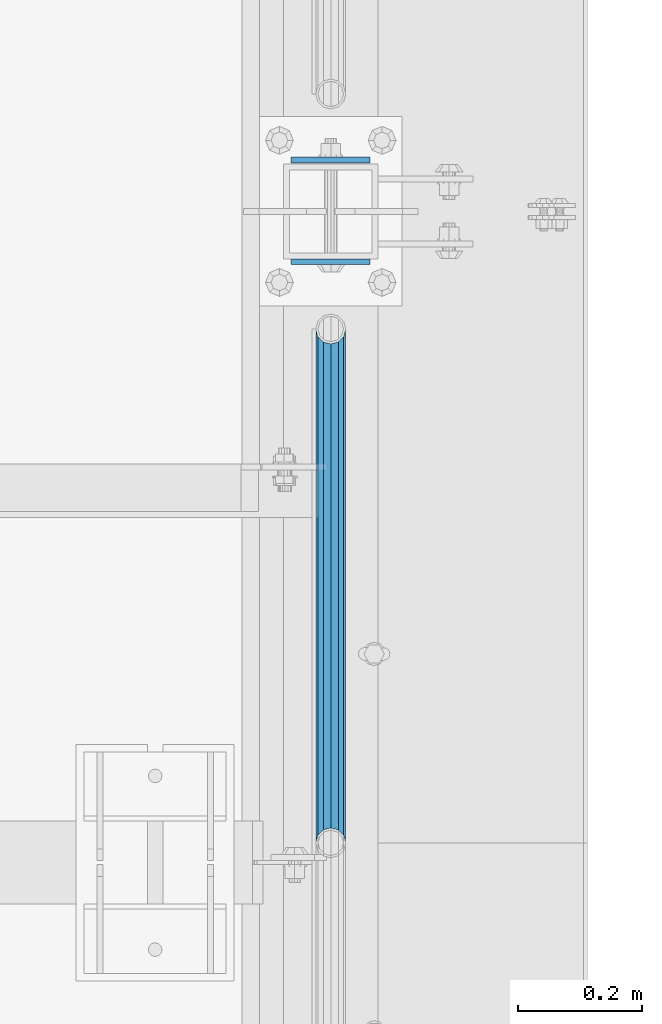
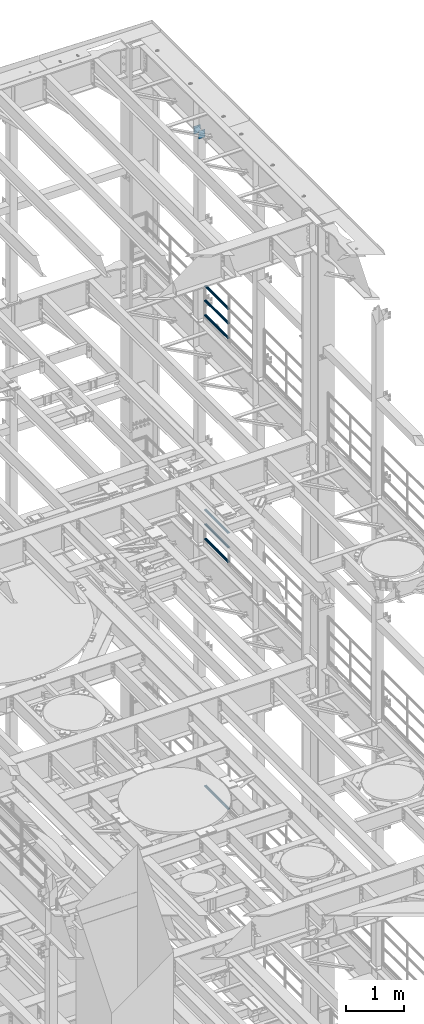
# One storey, part 1347 of 1876: 9 beams, 4 elements without a shape of their own.
"""IFC2X3 building model written with IfcOpenShell, lengths in millimetres."""

import ifcopenshell
import ifcopenshell.guid

model = None  # the IFC model being written
_history = None  # IfcOwnerHistory: only IFC2X3 demands one
_inside = {}  # id of a spatial element -> (the spatial element, [elements in it])
_under = {}  # id of a project, library or spatial element -> (it, [spatial elements below it])
_declared = {}  # id of a project -> (the project, [libraries it declares])
_typed = {}  # id of a type object -> (the type object, [elements of that type])
_made_of = {}  # id of a material, layer set ... -> (it, [elements and type objects made of it])


def new_model(schema):
    """Start an empty IFC model of exactly this schema.

    Asked for "IFC4X3", IfcOpenShell would pick the latest addendum, in which some entities
    have other attributes; the version numbers below select the first issue.
    IFC2X3 requires an IfcOwnerHistory on every rooted entity: one is made here for all.
    """
    global model, _history
    if schema == "IFC4X3":
        model = ifcopenshell.file(schema_version=(4, 3, 0, 0))
    else:
        model = ifcopenshell.file(schema=schema)
    _inside.clear()
    _under.clear()
    _declared.clear()
    _typed.clear()
    _made_of.clear()
    _history = None
    if model.schema == "IFC2X3":
        org = make("IfcOrganization", Name="unknown")
        user = make(
            "IfcPersonAndOrganization",
            ThePerson=make("IfcPerson", FamilyName="unknown"),
            TheOrganization=org,
        )
        app = make(
            "IfcApplication",
            ApplicationDeveloper=org,
            Version="unknown",
            ApplicationFullName="unknown",
            ApplicationIdentifier="unknown",
        )
        _history = make(
            "IfcOwnerHistory",
            OwningUser=user,
            OwningApplication=app,
            ChangeAction="ADDED",
            CreationDate=0,
        )
    return model


def make(cls, **values):
    """One entity of the class cls with the attributes given. An attribute that is None is left unset."""
    return model.create_entity(
        cls, **{name: value for name, value in values.items() if value is not None}
    )


def rooted(cls, **values):
    """An entity with a GlobalId (a new one), such as an element, a storey or a relation."""
    return make(cls, GlobalId=ifcopenshell.guid.new(), OwnerHistory=_history, **values)


def si_unit(unit_type, name, prefix=None):
    """IfcSIUnit, for example si_unit("LENGTHUNIT", "METRE", prefix="MILLI")."""
    return make("IfcSIUnit", UnitType=unit_type, Prefix=prefix, Name=name)


def assignment(units):
    """IfcUnitAssignment: the units of a project."""
    return None if units is None else make("IfcUnitAssignment", Units=units)


def point(xyz):
    """IfcCartesianPoint."""
    return None if xyz is None else make("IfcCartesianPoint", Coordinates=xyz)


def direction(xyz):
    """IfcDirection."""
    return None if xyz is None else make("IfcDirection", DirectionRatios=xyz)


def frame(location, z_axis=None, x_axis=None):
    """IfcAxis2Placement3D, a coordinate frame: its origin and axes. An axis left out is left unset."""
    return make(
        "IfcAxis2Placement3D",
        Location=point(location),
        Axis=direction(z_axis),
        RefDirection=direction(x_axis),
    )


def origin_with_axes():
    """The frame at (0, 0, 0) with the z axis (0, 0, 1) and the x axis (1, 0, 0) written out."""
    return frame((0.0, 0.0, 0.0), z_axis=(0.0, 0.0, 1.0), x_axis=(1.0, 0.0, 0.0))


def place(relative_to, where):
    """IfcLocalPlacement: puts the frame where relative to a parent placement (None: the world)."""
    return make(
        "IfcLocalPlacement", PlacementRelTo=relative_to, RelativePlacement=where
    )


def context(
    kind, dimensions, precision=None, world=None, true_north=None, identifier=None
):
    """IfcGeometricRepresentationContext, for example the 3D "Model" context."""
    return make(
        "IfcGeometricRepresentationContext",
        ContextIdentifier=identifier,
        ContextType=kind,
        CoordinateSpaceDimension=dimensions,
        Precision=precision,
        WorldCoordinateSystem=world,
        TrueNorth=true_north,
    )


def subcontext(parent, identifier, kind, view, scale=None):
    """IfcGeometricRepresentationSubContext, for example "Body" below "Model"."""
    return make(
        "IfcGeometricRepresentationSubContext",
        ContextIdentifier=identifier,
        ContextType=kind,
        ParentContext=parent,
        TargetScale=scale,
        TargetView=view,
    )


def project(units=None, contexts=None):
    """IfcProject with its units and contexts."""
    return rooted(
        "IfcProject",
        Name="project",
        RepresentationContexts=contexts,
        UnitsInContext=assignment(units),
    )


def spatial(cls, under=None, at=None, **own):
    """A site, building, storey or space (cls), placed at a placement, below another one or the project."""
    s = rooted(cls, ObjectPlacement=at, **own)
    if under is not None:
        _under.setdefault(under.id(), (under, []))[1].append(s)
    return s


def faces_of(points, faces, orient=None, outer=None):
    """IfcFace entities. A face is a list of loops; a loop is a list of indices into points, from 0.

    orient and outer hold one flag for each loop. By default every Orientation is true, the
    first loop of a face is its IfcFaceOuterBound and the others are IfcFaceBound.
    """
    made = []
    for i, loops in enumerate(faces):
        bounds = []
        for j, loop in enumerate(loops):
            is_outer = j == 0 if outer is None else outer[i][j]
            bounds.append(
                make(
                    "IfcFaceOuterBound" if is_outer else "IfcFaceBound",
                    Bound=make("IfcPolyLoop", Polygon=[points[k] for k in loop]),
                    Orientation=True if orient is None else orient[i][j],
                )
            )
        made.append(make("IfcFace", Bounds=bounds))
    return made


def faceted_brep(points, faces, orient=None, outer=None, voids=None):
    """IfcFacetedBrep: a solid bounded by flat faces; with voids (closed shells), ...WithVoids."""
    shared = [point(p) for p in points]
    hull = make("IfcClosedShell", CfsFaces=faces_of(shared, faces, orient, outer))
    if voids is None:
        return make("IfcFacetedBrep", Outer=hull)
    return make(
        "IfcFacetedBrepWithVoids",
        Outer=hull,
        Voids=[
            make(cls, CfsFaces=faces_of(shared, fs, o, b)) for cls, fs, o, b in voids
        ],
    )


def shape(context_of_items, identifier, shape_type, items):
    """IfcShapeRepresentation: the items that make up one representation, for example the "Body"."""
    return make(
        "IfcShapeRepresentation",
        ContextOfItems=context_of_items,
        RepresentationIdentifier=identifier,
        RepresentationType=shape_type,
        Items=items,
    )


def material(Name=None, Category=None):
    """IfcMaterial."""
    return make("IfcMaterial", Name=Name, Category=Category)


def made_of(thing, what):
    """Note that an element or type object is made of a material, layer set ...; save() writes the relation."""
    if what is not None:
        _made_of.setdefault(what.id(), (what, []))[1].append(thing)
    return thing


def type_object(cls, material=None, **own):
    """A type object (cls), such as IfcWallType, which elements share."""
    return made_of(rooted(cls, **own), material)


def element(
    cls,
    number,
    at=None,
    inside=None,
    cuts=None,
    type_object=None,
    material=None,
    context=None,
    identifier="Body",
    shape_type=None,
    held_by="IfcProductDefinitionShape",
    body=None,
    shapes=None,
    **own,
):
    """One element of the class cls, such as IfcWall. Its Tag is "e" and its number.

    at: its placement. inside: the storey or other place that contains it. cuts: it is an
    opening in that element (IfcRelVoidsElement). A single representation is given by context,
    identifier, shape_type and body (its items); several are given by shapes. held_by: the class
    of the entity that holds the representations. save() writes the other relations.
    """
    e = rooted(cls, Tag="e%d" % number, ObjectPlacement=at, **own)
    if body is not None:
        shapes = [shape(context, identifier, shape_type, body)]
    if shapes is not None:
        e.Representation = make(held_by, Representations=shapes)
    if inside is not None:
        _inside.setdefault(inside.id(), (inside, []))[1].append(e)
    if cuts is not None:
        rooted(
            "IfcRelVoidsElement", RelatingBuildingElement=cuts, RelatedOpeningElement=e
        )
    if type_object is not None:
        _typed.setdefault(type_object.id(), (type_object, []))[1].append(e)
    return made_of(e, material)


def aggregate(whole, parts):
    """IfcRelAggregates: a whole, such as a stair, and the parts it consists of."""
    return rooted("IfcRelAggregates", RelatingObject=whole, RelatedObjects=parts)


def save(model, path):
    """Write the relations noted so far, then the file.

    IfcRelAggregates (storeys below a building ...), IfcRelContainedInSpatialStructure (elements
    in a storey), IfcRelDefinesByType, IfcRelAssociatesMaterial and IfcRelDeclares: one each for
    every whole, place, type object, material and project.
    """
    for whole, parts in _under.values():
        aggregate(whole, parts)
    for where, things in _inside.values():
        rooted(
            "IfcRelContainedInSpatialStructure",
            RelatedElements=things,
            RelatingStructure=where,
        )
    for kind, things in _typed.values():
        rooted("IfcRelDefinesByType", RelatedObjects=things, RelatingType=kind)
    for what, things in _made_of.values():
        rooted("IfcRelAssociatesMaterial", RelatedObjects=things, RelatingMaterial=what)
    for by, libraries in _declared.values():
        rooted("IfcRelDeclares", RelatingContext=by, RelatedDefinitions=libraries)
    model.write(path)


model = new_model("IFC2X3")

# Units and contexts
model_context = context("Model", 3, precision=1e-05, world=origin_with_axes())
body_context = subcontext(model_context, "Body", "Model", "MODEL_VIEW")
ifc_project = project(units=[si_unit("LENGTHUNIT", "METRE", prefix="MILLI"), si_unit("AREAUNIT", "SQUARE_METRE"), si_unit("VOLUMEUNIT", "CUBIC_METRE"), si_unit("MASSUNIT", "GRAM", prefix="KILO"), si_unit("TIMEUNIT", "SECOND"), si_unit("PLANEANGLEUNIT", "RADIAN"), si_unit("SOLIDANGLEUNIT", "STERADIAN"), si_unit("THERMODYNAMICTEMPERATUREUNIT", "DEGREE_CELSIUS"), si_unit("LUMINOUSINTENSITYUNIT", "LUMEN")], contexts=[model_context])

# Site, building, storey
site_placement = place(None, origin_with_axes())
site = spatial("IfcSite", under=ifc_project, at=site_placement, CompositionType="ELEMENT")
building_placement = place(site_placement, origin_with_axes())
building = spatial("IfcBuilding", under=site, at=building_placement, Name="Undefined", CompositionType="ELEMENT")
storey_placement = place(building_placement, origin_with_axes())
storey = spatial("IfcBuildingStorey", under=building, at=storey_placement, Name="Undefined", CompositionType="ELEMENT", Elevation=0.0)

# Assembly, beams
assembly_1_placement = place(storey_placement, origin_with_axes())
assembly_1 = element("IfcElementAssembly", 1, at=assembly_1_placement, inside=storey, Name="RAIL", AssemblyPlace="NOTDEFINED", PredefinedType="RIGID_FRAME")
ifc_material_1 = material()
beam_type_1 = type_object("IfcBeamType", Name="PIPE1-1/2SCH40", PredefinedType="NOTDEFINED")
beam_1_placement = place(assembly_1_placement, frame((7620.0, 11494.77, 18145.125), z_axis=(0.0, 0.0, 1.0), x_axis=(0.0, -1.0, 0.0)))
beam_1 = element("IfcBeam", 2, at=beam_1_placement, type_object=beam_type_1, material=ifc_material_1, Name="RAIL", ObjectType="PIPE1-1/2SCH40", context=body_context, shape_type="Brep", body=[
    faceted_brep([(805.872807006681, -12.0649999999996, 20.8971929933177), (805.872807006683, -12.0649999999996, 15.8661214311796), (805.379378568819, -10.2235000000001, 17.7076214311819), (802.640000000001, 0.0, 20.4470000000001), (802.640000000001, 0.0, 24.130000000001), (805.379378568819, 10.2235000000001, 17.7076214311819), (805.872807006683, 12.0649999999996, 15.8661214311796), (805.872807006681, 12.0649999999996, 20.8971929933177), (826.77, 24.1300000000001, 0.0), (814.705, 20.8971929933186, 12.0649999999987), (814.705, 20.8971929933186, -12.0649999999987), (811.515428437862, 17.7076214311801, 10.2235000000001), (814.254807006682, 20.4470000000001, 0.0), (811.515428437862, 17.7076214311801, -10.2235000000001), (805.872807006683, 12.0649999999996, -15.8661214311796), (805.872807006681, 12.0649999999996, -20.8971929933177), (805.379378568819, 10.2235000000001, -17.7076214311819), (802.640000000001, 0.0, -20.4470000000001), (802.640000000001, 0.0, -24.130000000001), (805.872807006683, -12.0649999999996, -15.8661214311796), (805.872807006681, -12.0649999999996, -20.8971929933177), (805.379378568819, -10.2235000000001, -17.7076214311819), (826.77, -24.1300000000001, 0.0), (814.705, -20.8971929933186, -12.0649999999987), (814.705, -20.8971929933186, 12.0649999999987), (811.515428437862, -17.7076214311801, -10.2235000000001), (814.254807006682, -20.4470000000001, 0.0), (811.515428437862, -17.7076214311801, 10.2235000000001), (12.0650000000064, -20.8971929933177, -12.0649999999987), (20.8971929933249, -12.0650000000005, -20.8971929933177), (0.0, 24.1299999999992, 0.0), (12.0650000000064, 20.8971929933177, -12.0649999999987), (12.0650000000064, 20.8971929933177, 12.0649999999987), (20.8971929933249, 12.0650000000005, 20.8971929933177), (24.1300000000064, 0.0, 24.130000000001), (20.8971929933249, 12.0650000000005, -20.8971929933177), (24.1300000000063, 0.0, -24.130000000001), (24.1300000000063, 0.0, -20.4470000000001), (20.8971929933249, -12.0650000000005, -15.8661214311796), (21.3906214311868, -10.2235000000001, -17.7076214311819), (21.3906214311868, 10.2235000000001, -17.7076214311819), (20.8971929933249, 12.0650000000005, -15.8661214311796), (15.2545715621445, 17.7076214311801, -10.2235000000001), (12.5151929933249, 20.4470000000001, 0.0), (15.2545715621445, 17.7076214311801, 10.2235000000001), (20.8971929933249, 12.0650000000005, 15.8661214311796), (21.3906214311868, 10.2235000000001, 17.7076214311819), (24.1300000000064, 0.0, 20.4470000000001), (21.3906214311868, -10.2235000000001, 17.7076214311819), (20.8971929933249, -12.0650000000005, 15.8661214311796), (20.8971929933249, -12.0650000000005, 20.8971929933177), (12.0650000000064, -20.8971929933177, 12.0649999999987), (0.0, -24.1299999999992, 0.0), (15.2545715621445, -17.7076214311801, 10.2235000000001), (12.5151929933249, -20.4470000000001, 0.0), (15.2545715621445, -17.7076214311801, -10.2235000000001)], [[[0, 1, 2, 3, 4]], [[4, 3, 5, 6, 7]], [[8, 9, 10]], [[7, 6, 11, 12, 13, 14, 15, 10, 9]], [[16, 17, 18, 15, 14]], [[19, 20, 18, 17, 21]], [[22, 23, 24]], [[24, 23, 20, 19, 25, 26, 27, 1, 0]], [[28, 29, 20, 23]], [[30, 31, 32]], [[33, 34, 4, 7]], [[32, 33, 7, 9]], [[30, 32, 9, 8]], [[31, 30, 8, 10]], [[35, 31, 10, 15]], [[36, 35, 15, 18]], [[29, 36, 18, 20]], [[37, 36, 29, 38, 39]], [[40, 41, 35, 36, 37]], [[32, 31, 35, 41, 42, 43, 44, 45, 33]], [[33, 45, 46, 47, 34]], [[34, 47, 48, 49, 50]], [[34, 50, 0, 4]], [[50, 51, 24, 0]], [[51, 52, 22, 24]], [[52, 28, 23, 22]], [[51, 28, 52]], [[50, 49, 53, 54, 55, 38, 29, 28, 51]], [[55, 54, 26, 25]], [[21, 39, 38, 55, 25, 19]], [[37, 39, 21, 17]], [[40, 37, 17, 16]], [[42, 41, 40, 16, 14, 13]], [[43, 42, 13, 12]], [[44, 43, 12, 11]], [[5, 46, 45, 44, 11, 6]], [[47, 46, 5, 3]], [[48, 47, 3, 2]], [[53, 49, 48, 2, 1, 27]], [[54, 53, 27, 26]]]),
])
beam_2_placement = place(assembly_1_placement, frame((7620.0, 10668.0, 18449.925), z_axis=(0.0, 0.0, -1.0), x_axis=(0.0, 1.0, 0.0)))
beam_2 = element("IfcBeam", 3, at=beam_2_placement, type_object=beam_type_1, material=ifc_material_1, Name="RAIL", ObjectType="PIPE1-1/2SCH40", context=body_context, shape_type="Brep", body=[
    faceted_brep([(0.0, 24.1299999999992, 0.0), (12.0650000000064, 20.8971929933177, -12.0649999999987), (12.0650000000064, 20.8971929933177, 12.0649999999987), (12.0650000000064, -20.8971929933177, 12.0649999999987), (12.0650000000064, -20.8971929933177, -12.0649999999987), (0.0, -24.1299999999992, 0.0), (20.8971929933249, -12.0650000000005, 20.8971929933177), (20.8971929933249, -12.0650000000005, 15.8661214311796), (15.2545715621445, -17.7076214311801, 10.2235000000001), (12.5151929933249, -20.4470000000001, 0.0), (15.2545715621445, -17.7076214311801, -10.2235000000001), (20.8971929933249, -12.0650000000005, -15.8661214311796), (20.8971929933249, -12.0650000000005, -20.8971929933177), (24.1300000000063, 0.0, -20.4470000000001), (24.1300000000063, 0.0, -24.130000000001), (21.3906214311868, -10.2235000000001, -17.7076214311819), (21.3906214311868, 10.2235000000001, -17.7076214311819), (20.8971929933249, 12.0650000000005, -15.8661214311796), (20.8971929933249, 12.0650000000005, -20.8971929933177), (15.2545715621445, 17.7076214311801, -10.2235000000001), (12.5151929933249, 20.4470000000001, 0.0), (15.2545715621445, 17.7076214311801, 10.2235000000001), (20.8971929933249, 12.0650000000005, 15.8661214311796), (20.8971929933249, 12.0650000000005, 20.8971929933177), (21.3906214311868, 10.2235000000001, 17.7076214311819), (24.1300000000064, 0.0, 20.4470000000001), (24.1300000000064, 0.0, 24.130000000001), (21.3906214311868, -10.2235000000001, 17.7076214311819), (826.77, 24.1300000000001, 0.0), (814.705, 20.8971929933186, -12.0649999999987), (805.872807006681, 12.0649999999996, -20.8971929933177), (826.77, -24.1300000000001, 0.0), (814.705, -20.8971929933186, -12.0649999999987), (814.705, -20.8971929933186, 12.0649999999987), (805.872807006681, -12.0649999999996, 20.8971929933177), (805.872807006681, -12.0649999999996, -20.8971929933177), (802.640000000001, 0.0, -24.130000000001), (805.379378568819, 10.2235000000001, -17.7076214311819), (802.640000000001, 0.0, -20.4470000000001), (805.872807006683, 12.0649999999996, -15.8661214311796), (805.872807006683, -12.0649999999996, -15.8661214311796), (805.379378568819, -10.2235000000001, -17.7076214311819), (811.515428437862, -17.7076214311801, -10.2235000000001), (814.254807006682, -20.4470000000001, 0.0), (811.515428437862, -17.7076214311801, 10.2235000000001), (805.872807006683, -12.0649999999996, 15.8661214311796), (805.379378568819, -10.2235000000001, 17.7076214311819), (802.640000000001, 0.0, 20.4470000000001), (802.640000000001, 0.0, 24.130000000001), (805.872807006681, 12.0649999999996, 20.8971929933177), (814.705, 20.8971929933186, 12.0649999999987), (805.872807006683, 12.0649999999996, 15.8661214311796), (811.515428437862, 17.7076214311801, 10.2235000000001), (814.254807006682, 20.4470000000001, 0.0), (811.515428437862, 17.7076214311801, -10.2235000000001), (805.379378568819, 10.2235000000001, 17.7076214311819)], [[[0, 1, 2]], [[3, 4, 5]], [[6, 7, 8, 9, 10, 11, 12, 4, 3]], [[13, 14, 12, 11, 15]], [[16, 17, 18, 14, 13]], [[2, 1, 18, 17, 19, 20, 21, 22, 23]], [[23, 22, 24, 25, 26]], [[26, 25, 27, 7, 6]], [[1, 0, 28, 29]], [[18, 1, 29, 30]], [[31, 32, 33]], [[6, 3, 33, 34]], [[3, 5, 31, 33]], [[5, 4, 32, 31]], [[4, 12, 35, 32]], [[12, 14, 36, 35]], [[14, 18, 30, 36]], [[37, 38, 36, 30, 39]], [[40, 35, 36, 38, 41]], [[33, 32, 35, 40, 42, 43, 44, 45, 34]], [[34, 45, 46, 47, 48]], [[26, 6, 34, 48]], [[2, 23, 49, 50]], [[23, 26, 48, 49]], [[0, 2, 50, 28]], [[28, 50, 29]], [[49, 51, 52, 53, 54, 39, 30, 29, 50]], [[48, 47, 55, 51, 49]], [[25, 24, 55, 47]], [[55, 24, 22, 21, 52, 51]], [[21, 20, 53, 52]], [[20, 19, 54, 53]], [[19, 17, 16, 37, 39, 54]], [[16, 13, 38, 37]], [[13, 15, 41, 38]], [[41, 15, 11, 10, 42, 40]], [[10, 9, 43, 42]], [[9, 8, 44, 43]], [[8, 7, 27, 46, 45, 44]], [[27, 25, 47, 46]]]),
])
beam_3_placement = place(assembly_1_placement, frame((7620.0, 10668.0, 18754.725), z_axis=(0.0, 0.0, -1.0), x_axis=(0.0, 1.0, 0.0)))
beam_3 = element("IfcBeam", 4, at=beam_3_placement, type_object=beam_type_1, material=ifc_material_1, Name="RAIL", ObjectType="PIPE1-1/2SCH40", context=body_context, shape_type="Brep", body=[
    faceted_brep([(0.0, 24.1299999999992, 0.0), (12.0650000000064, 20.8971929933177, -12.0649999999987), (12.0650000000064, 20.8971929933177, 12.0649999999987), (12.0650000000064, -20.8971929933177, 12.0649999999987), (12.0650000000064, -20.8971929933177, -12.0649999999987), (0.0, -24.1299999999992, 0.0), (20.8971929933249, -12.0650000000005, 20.8971929933177), (20.8971929933249, -12.0650000000005, 15.8661214311796), (15.2545715621445, -17.7076214311801, 10.2235000000001), (12.5151929933249, -20.4470000000001, 0.0), (15.2545715621445, -17.7076214311801, -10.2235000000001), (20.8971929933249, -12.0650000000005, -15.8661214311796), (20.8971929933249, -12.0650000000005, -20.8971929933177), (24.1300000000063, 0.0, -20.4470000000001), (24.1300000000063, 0.0, -24.130000000001), (21.3906214311868, -10.2235000000001, -17.7076214311819), (21.3906214311868, 10.2235000000001, -17.7076214311819), (20.8971929933249, 12.0650000000005, -15.8661214311796), (20.8971929933249, 12.0650000000005, -20.8971929933177), (15.2545715621445, 17.7076214311801, -10.2235000000001), (12.5151929933249, 20.4470000000001, 0.0), (15.2545715621445, 17.7076214311801, 10.2235000000001), (20.8971929933249, 12.0650000000005, 15.8661214311796), (20.8971929933249, 12.0650000000005, 20.8971929933177), (21.3906214311868, 10.2235000000001, 17.7076214311819), (24.1300000000064, 0.0, 20.4470000000001), (24.1300000000064, 0.0, 24.130000000001), (21.3906214311868, -10.2235000000001, 17.7076214311819), (826.77, 24.1300000000001, 0.0), (814.705, 20.8971929933186, -12.0649999999987), (805.872807006681, 12.0649999999996, -20.8971929933177), (826.77, -24.1300000000001, 0.0), (814.705, -20.8971929933186, -12.0649999999987), (814.705, -20.8971929933186, 12.0649999999987), (805.872807006681, -12.0649999999996, 20.8971929933177), (805.872807006681, -12.0649999999996, -20.8971929933177), (802.640000000001, 0.0, -24.130000000001), (805.379378568819, 10.2235000000001, -17.7076214311819), (802.640000000001, 0.0, -20.4470000000001), (805.872807006683, 12.0649999999996, -15.8661214311796), (805.872807006683, -12.0649999999996, -15.8661214311796), (805.379378568819, -10.2235000000001, -17.7076214311819), (811.515428437862, -17.7076214311801, -10.2235000000001), (814.254807006682, -20.4470000000001, 0.0), (811.515428437862, -17.7076214311801, 10.2235000000001), (805.872807006683, -12.0649999999996, 15.8661214311796), (805.379378568819, -10.2235000000001, 17.7076214311819), (802.640000000001, 0.0, 20.4470000000001), (802.640000000001, 0.0, 24.130000000001), (805.872807006681, 12.0649999999996, 20.8971929933177), (814.705, 20.8971929933186, 12.0649999999987), (805.872807006683, 12.0649999999996, 15.8661214311796), (811.515428437862, 17.7076214311801, 10.2235000000001), (814.254807006682, 20.4470000000001, 0.0), (811.515428437862, 17.7076214311801, -10.2235000000001), (805.379378568819, 10.2235000000001, 17.7076214311819)], [[[0, 1, 2]], [[3, 4, 5]], [[6, 7, 8, 9, 10, 11, 12, 4, 3]], [[13, 14, 12, 11, 15]], [[16, 17, 18, 14, 13]], [[2, 1, 18, 17, 19, 20, 21, 22, 23]], [[23, 22, 24, 25, 26]], [[26, 25, 27, 7, 6]], [[1, 0, 28, 29]], [[18, 1, 29, 30]], [[31, 32, 33]], [[6, 3, 33, 34]], [[3, 5, 31, 33]], [[5, 4, 32, 31]], [[4, 12, 35, 32]], [[12, 14, 36, 35]], [[14, 18, 30, 36]], [[37, 38, 36, 30, 39]], [[40, 35, 36, 38, 41]], [[33, 32, 35, 40, 42, 43, 44, 45, 34]], [[34, 45, 46, 47, 48]], [[26, 6, 34, 48]], [[2, 23, 49, 50]], [[23, 26, 48, 49]], [[0, 2, 50, 28]], [[28, 50, 29]], [[49, 51, 52, 53, 54, 39, 30, 29, 50]], [[48, 47, 55, 51, 49]], [[25, 24, 55, 47]], [[55, 24, 22, 21, 52, 51]], [[21, 20, 53, 52]], [[20, 19, 54, 53]], [[19, 17, 16, 37, 39, 54]], [[16, 13, 38, 37]], [[13, 15, 41, 38]], [[41, 15, 11, 10, 42, 40]], [[10, 9, 43, 42]], [[9, 8, 44, 43]], [[8, 7, 27, 46, 45, 44]], [[27, 25, 47, 46]]]),
])
aggregate(assembly_1, [beam_1, beam_2, beam_3])

assembly_2_placement = place(storey_placement, origin_with_axes())
assembly_2 = element("IfcElementAssembly", 5, at=assembly_2_placement, inside=storey, Name="RAIL", AssemblyPlace="NOTDEFINED", PredefinedType="RIGID_FRAME")
beam_4_placement = place(assembly_2_placement, frame((7620.0, 11494.77, 13471.525), z_axis=(0.0, 0.0, 1.0), x_axis=(0.0, -1.0, 0.0)))
beam_4 = element("IfcBeam", 6, at=beam_4_placement, type_object=beam_type_1, material=ifc_material_1, Name="RAIL", ObjectType="PIPE1-1/2SCH40", context=body_context, shape_type="Brep", body=[
    faceted_brep([(805.872807006681, -12.0649999999996, 20.8971929933177), (805.872807006683, -12.0649999999996, 15.8661214311796), (805.379378568819, -10.2235000000001, 17.7076214311819), (802.640000000001, 0.0, 20.4470000000001), (802.640000000001, 0.0, 24.130000000001), (805.379378568819, 10.2235000000001, 17.7076214311819), (805.872807006683, 12.0649999999996, 15.8661214311796), (805.872807006681, 12.0649999999996, 20.8971929933177), (826.77, 24.1300000000001, 0.0), (814.705, 20.8971929933186, 12.0649999999987), (814.705, 20.8971929933186, -12.0649999999987), (811.515428437862, 17.7076214311801, 10.2235000000001), (814.254807006682, 20.4470000000001, 0.0), (811.515428437862, 17.7076214311801, -10.2235000000001), (805.872807006683, 12.0649999999996, -15.8661214311796), (805.872807006681, 12.0649999999996, -20.8971929933177), (805.379378568819, 10.2235000000001, -17.7076214311819), (802.640000000001, 0.0, -20.4470000000001), (802.640000000001, 0.0, -24.130000000001), (805.872807006683, -12.0649999999996, -15.8661214311796), (805.872807006681, -12.0649999999996, -20.8971929933177), (805.379378568819, -10.2235000000001, -17.7076214311819), (826.77, -24.1300000000001, 0.0), (814.705, -20.8971929933186, -12.0649999999987), (814.705, -20.8971929933186, 12.0649999999987), (811.515428437862, -17.7076214311801, -10.2235000000001), (814.254807006682, -20.4470000000001, 0.0), (811.515428437862, -17.7076214311801, 10.2235000000001), (12.0650000000064, -20.8971929933177, -12.0649999999987), (20.8971929933249, -12.0650000000005, -20.8971929933177), (0.0, 24.1299999999992, 0.0), (12.0650000000064, 20.8971929933177, -12.0649999999987), (12.0650000000064, 20.8971929933177, 12.0649999999987), (20.8971929933249, 12.0650000000005, 20.8971929933177), (24.1300000000064, 0.0, 24.130000000001), (20.8971929933249, 12.0650000000005, -20.8971929933177), (24.1300000000063, 0.0, -24.130000000001), (24.1300000000063, 0.0, -20.4470000000001), (20.8971929933249, -12.0650000000005, -15.8661214311796), (21.3906214311868, -10.2235000000001, -17.7076214311819), (21.3906214311868, 10.2235000000001, -17.7076214311819), (20.8971929933249, 12.0650000000005, -15.8661214311796), (15.2545715621445, 17.7076214311801, -10.2235000000001), (12.5151929933249, 20.4470000000001, 0.0), (15.2545715621445, 17.7076214311801, 10.2235000000001), (20.8971929933249, 12.0650000000005, 15.8661214311796), (21.3906214311868, 10.2235000000001, 17.7076214311819), (24.1300000000064, 0.0, 20.4470000000001), (21.3906214311868, -10.2235000000001, 17.7076214311819), (20.8971929933249, -12.0650000000005, 15.8661214311796), (20.8971929933249, -12.0650000000005, 20.8971929933177), (12.0650000000064, -20.8971929933177, 12.0649999999987), (0.0, -24.1299999999992, 0.0), (15.2545715621445, -17.7076214311801, 10.2235000000001), (12.5151929933249, -20.4470000000001, 0.0), (15.2545715621445, -17.7076214311801, -10.2235000000001)], [[[0, 1, 2, 3, 4]], [[4, 3, 5, 6, 7]], [[8, 9, 10]], [[7, 6, 11, 12, 13, 14, 15, 10, 9]], [[16, 17, 18, 15, 14]], [[19, 20, 18, 17, 21]], [[22, 23, 24]], [[24, 23, 20, 19, 25, 26, 27, 1, 0]], [[28, 29, 20, 23]], [[30, 31, 32]], [[33, 34, 4, 7]], [[32, 33, 7, 9]], [[30, 32, 9, 8]], [[31, 30, 8, 10]], [[35, 31, 10, 15]], [[36, 35, 15, 18]], [[29, 36, 18, 20]], [[37, 36, 29, 38, 39]], [[40, 41, 35, 36, 37]], [[32, 31, 35, 41, 42, 43, 44, 45, 33]], [[33, 45, 46, 47, 34]], [[34, 47, 48, 49, 50]], [[34, 50, 0, 4]], [[50, 51, 24, 0]], [[51, 52, 22, 24]], [[52, 28, 23, 22]], [[51, 28, 52]], [[50, 49, 53, 54, 55, 38, 29, 28, 51]], [[55, 54, 26, 25]], [[21, 39, 38, 55, 25, 19]], [[37, 39, 21, 17]], [[40, 37, 17, 16]], [[42, 41, 40, 16, 14, 13]], [[43, 42, 13, 12]], [[44, 43, 12, 11]], [[5, 46, 45, 44, 11, 6]], [[47, 46, 5, 3]], [[48, 47, 3, 2]], [[53, 49, 48, 2, 1, 27]], [[54, 53, 27, 26]]]),
])
beam_5_placement = place(assembly_2_placement, frame((7620.0, 10668.0, 13776.325), z_axis=(0.0, 0.0, -1.0), x_axis=(0.0, 1.0, 0.0)))
beam_5 = element("IfcBeam", 7, at=beam_5_placement, type_object=beam_type_1, material=ifc_material_1, Name="RAIL", ObjectType="PIPE1-1/2SCH40", context=body_context, shape_type="Brep", body=[
    faceted_brep([(0.0, 24.1299999999992, 0.0), (12.0650000000064, 20.8971929933177, -12.0649999999987), (12.0650000000064, 20.8971929933177, 12.0649999999987), (12.0650000000064, -20.8971929933177, 12.0649999999987), (12.0650000000064, -20.8971929933177, -12.0649999999987), (0.0, -24.1299999999992, 0.0), (20.8971929933249, -12.0650000000005, 20.8971929933177), (20.8971929933249, -12.0650000000005, 15.8661214311796), (15.2545715621445, -17.7076214311801, 10.2235000000001), (12.5151929933249, -20.4470000000001, 0.0), (15.2545715621445, -17.7076214311801, -10.2235000000001), (20.8971929933249, -12.0650000000005, -15.8661214311796), (20.8971929933249, -12.0650000000005, -20.8971929933177), (24.1300000000063, 0.0, -20.4470000000001), (24.1300000000063, 0.0, -24.130000000001), (21.3906214311868, -10.2235000000001, -17.7076214311819), (21.3906214311868, 10.2235000000001, -17.7076214311819), (20.8971929933249, 12.0650000000005, -15.8661214311796), (20.8971929933249, 12.0650000000005, -20.8971929933177), (15.2545715621445, 17.7076214311801, -10.2235000000001), (12.5151929933249, 20.4470000000001, 0.0), (15.2545715621445, 17.7076214311801, 10.2235000000001), (20.8971929933249, 12.0650000000005, 15.8661214311796), (20.8971929933249, 12.0650000000005, 20.8971929933177), (21.3906214311868, 10.2235000000001, 17.7076214311819), (24.1300000000064, 0.0, 20.4470000000001), (24.1300000000064, 0.0, 24.130000000001), (21.3906214311868, -10.2235000000001, 17.7076214311819), (826.77, 24.1300000000001, 0.0), (814.705, 20.8971929933186, -12.0649999999987), (805.872807006681, 12.0649999999996, -20.8971929933177), (826.77, -24.1300000000001, 0.0), (814.705, -20.8971929933186, -12.0649999999987), (814.705, -20.8971929933186, 12.0649999999987), (805.872807006681, -12.0649999999996, 20.8971929933177), (805.872807006681, -12.0649999999996, -20.8971929933177), (802.640000000001, 0.0, -24.130000000001), (805.379378568819, 10.2235000000001, -17.7076214311819), (802.640000000001, 0.0, -20.4470000000001), (805.872807006683, 12.0649999999996, -15.8661214311796), (805.872807006683, -12.0649999999996, -15.8661214311796), (805.379378568819, -10.2235000000001, -17.7076214311819), (811.515428437862, -17.7076214311801, -10.2235000000001), (814.254807006682, -20.4470000000001, 0.0), (811.515428437862, -17.7076214311801, 10.2235000000001), (805.872807006683, -12.0649999999996, 15.8661214311796), (805.379378568819, -10.2235000000001, 17.7076214311819), (802.640000000001, 0.0, 20.4470000000001), (802.640000000001, 0.0, 24.130000000001), (805.872807006681, 12.0649999999996, 20.8971929933177), (814.705, 20.8971929933186, 12.0649999999987), (805.872807006683, 12.0649999999996, 15.8661214311796), (811.515428437862, 17.7076214311801, 10.2235000000001), (814.254807006682, 20.4470000000001, 0.0), (811.515428437862, 17.7076214311801, -10.2235000000001), (805.379378568819, 10.2235000000001, 17.7076214311819)], [[[0, 1, 2]], [[3, 4, 5]], [[6, 7, 8, 9, 10, 11, 12, 4, 3]], [[13, 14, 12, 11, 15]], [[16, 17, 18, 14, 13]], [[2, 1, 18, 17, 19, 20, 21, 22, 23]], [[23, 22, 24, 25, 26]], [[26, 25, 27, 7, 6]], [[1, 0, 28, 29]], [[18, 1, 29, 30]], [[31, 32, 33]], [[6, 3, 33, 34]], [[3, 5, 31, 33]], [[5, 4, 32, 31]], [[4, 12, 35, 32]], [[12, 14, 36, 35]], [[14, 18, 30, 36]], [[37, 38, 36, 30, 39]], [[40, 35, 36, 38, 41]], [[33, 32, 35, 40, 42, 43, 44, 45, 34]], [[34, 45, 46, 47, 48]], [[26, 6, 34, 48]], [[2, 23, 49, 50]], [[23, 26, 48, 49]], [[0, 2, 50, 28]], [[28, 50, 29]], [[49, 51, 52, 53, 54, 39, 30, 29, 50]], [[48, 47, 55, 51, 49]], [[25, 24, 55, 47]], [[55, 24, 22, 21, 52, 51]], [[21, 20, 53, 52]], [[20, 19, 54, 53]], [[19, 17, 16, 37, 39, 54]], [[16, 13, 38, 37]], [[13, 15, 41, 38]], [[41, 15, 11, 10, 42, 40]], [[10, 9, 43, 42]], [[9, 8, 44, 43]], [[8, 7, 27, 46, 45, 44]], [[27, 25, 47, 46]]]),
])
beam_6_placement = place(assembly_2_placement, frame((7620.0, 10668.0, 14081.125), z_axis=(0.0, 0.0, -1.0), x_axis=(0.0, 1.0, 0.0)))
beam_6 = element("IfcBeam", 8, at=beam_6_placement, type_object=beam_type_1, material=ifc_material_1, Name="RAIL", ObjectType="PIPE1-1/2SCH40", context=body_context, shape_type="Brep", body=[
    faceted_brep([(0.0, 24.1299999999992, 0.0), (12.0650000000064, 20.8971929933177, -12.0649999999987), (12.0650000000064, 20.8971929933177, 12.0649999999987), (12.0650000000064, -20.8971929933177, 12.0649999999987), (12.0650000000064, -20.8971929933177, -12.0649999999987), (0.0, -24.1299999999992, 0.0), (20.8971929933249, -12.0650000000005, 20.8971929933177), (20.8971929933249, -12.0650000000005, 15.8661214311796), (15.2545715621445, -17.7076214311801, 10.2235000000001), (12.5151929933249, -20.4470000000001, 0.0), (15.2545715621445, -17.7076214311801, -10.2235000000001), (20.8971929933249, -12.0650000000005, -15.8661214311796), (20.8971929933249, -12.0650000000005, -20.8971929933177), (24.1300000000063, 0.0, -20.4470000000001), (24.1300000000063, 0.0, -24.130000000001), (21.3906214311868, -10.2235000000001, -17.7076214311819), (21.3906214311868, 10.2235000000001, -17.7076214311819), (20.8971929933249, 12.0650000000005, -15.8661214311796), (20.8971929933249, 12.0650000000005, -20.8971929933177), (15.2545715621445, 17.7076214311801, -10.2235000000001), (12.5151929933249, 20.4470000000001, 0.0), (15.2545715621445, 17.7076214311801, 10.2235000000001), (20.8971929933249, 12.0650000000005, 15.8661214311796), (20.8971929933249, 12.0650000000005, 20.8971929933177), (21.3906214311868, 10.2235000000001, 17.7076214311819), (24.1300000000064, 0.0, 20.4470000000001), (24.1300000000064, 0.0, 24.130000000001), (21.3906214311868, -10.2235000000001, 17.7076214311819), (826.77, 24.1300000000001, 0.0), (814.705, 20.8971929933186, -12.0649999999987), (805.872807006681, 12.0649999999996, -20.8971929933177), (826.77, -24.1300000000001, 0.0), (814.705, -20.8971929933186, -12.0649999999987), (814.705, -20.8971929933186, 12.0649999999987), (805.872807006681, -12.0649999999996, 20.8971929933177), (805.872807006681, -12.0649999999996, -20.8971929933177), (802.640000000001, 0.0, -24.130000000001), (805.379378568819, 10.2235000000001, -17.7076214311819), (802.640000000001, 0.0, -20.4470000000001), (805.872807006683, 12.0649999999996, -15.8661214311796), (805.872807006683, -12.0649999999996, -15.8661214311796), (805.379378568819, -10.2235000000001, -17.7076214311819), (811.515428437862, -17.7076214311801, -10.2235000000001), (814.254807006682, -20.4470000000001, 0.0), (811.515428437862, -17.7076214311801, 10.2235000000001), (805.872807006683, -12.0649999999996, 15.8661214311796), (805.379378568819, -10.2235000000001, 17.7076214311819), (802.640000000001, 0.0, 20.4470000000001), (802.640000000001, 0.0, 24.130000000001), (805.872807006681, 12.0649999999996, 20.8971929933177), (814.705, 20.8971929933186, 12.0649999999987), (805.872807006683, 12.0649999999996, 15.8661214311796), (811.515428437862, 17.7076214311801, 10.2235000000001), (814.254807006682, 20.4470000000001, 0.0), (811.515428437862, 17.7076214311801, -10.2235000000001), (805.379378568819, 10.2235000000001, 17.7076214311819)], [[[0, 1, 2]], [[3, 4, 5]], [[6, 7, 8, 9, 10, 11, 12, 4, 3]], [[13, 14, 12, 11, 15]], [[16, 17, 18, 14, 13]], [[2, 1, 18, 17, 19, 20, 21, 22, 23]], [[23, 22, 24, 25, 26]], [[26, 25, 27, 7, 6]], [[1, 0, 28, 29]], [[18, 1, 29, 30]], [[31, 32, 33]], [[6, 3, 33, 34]], [[3, 5, 31, 33]], [[5, 4, 32, 31]], [[4, 12, 35, 32]], [[12, 14, 36, 35]], [[14, 18, 30, 36]], [[37, 38, 36, 30, 39]], [[40, 35, 36, 38, 41]], [[33, 32, 35, 40, 42, 43, 44, 45, 34]], [[34, 45, 46, 47, 48]], [[26, 6, 34, 48]], [[2, 23, 49, 50]], [[23, 26, 48, 49]], [[0, 2, 50, 28]], [[28, 50, 29]], [[49, 51, 52, 53, 54, 39, 30, 29, 50]], [[48, 47, 55, 51, 49]], [[25, 24, 55, 47]], [[55, 24, 22, 21, 52, 51]], [[21, 20, 53, 52]], [[20, 19, 54, 53]], [[19, 17, 16, 37, 39, 54]], [[16, 13, 38, 37]], [[13, 15, 41, 38]], [[41, 15, 11, 10, 42, 40]], [[10, 9, 43, 42]], [[9, 8, 44, 43]], [[8, 7, 27, 46, 45, 44]], [[27, 25, 47, 46]]]),
])
aggregate(assembly_2, [beam_4, beam_5, beam_6])

# Assembly, beam
assembly_3_placement = place(storey_placement, origin_with_axes())
assembly_3 = element("IfcElementAssembly", 9, at=assembly_3_placement, inside=storey, Name="RAIL", AssemblyPlace="NOTDEFINED", PredefinedType="RIGID_FRAME")
beam_7_placement = place(assembly_3_placement, frame((7620.0, 11494.77, 8315.325), z_axis=(0.0, 0.0, 1.0), x_axis=(0.0, -1.0, 0.0)))
beam_7 = element("IfcBeam", 10, at=beam_7_placement, type_object=beam_type_1, material=ifc_material_1, Name="RAIL", ObjectType="PIPE1-1/2SCH40", context=body_context, shape_type="Brep", body=[
    faceted_brep([(805.872807006681, -12.0649999999996, 20.8971929933177), (805.872807006683, -12.0649999999996, 15.8661214311796), (805.379378568819, -10.2235000000001, 17.7076214311819), (802.640000000001, 0.0, 20.4470000000001), (802.640000000001, 0.0, 24.130000000001), (805.379378568819, 10.2235000000001, 17.7076214311819), (805.872807006683, 12.0649999999996, 15.8661214311796), (805.872807006681, 12.0649999999996, 20.8971929933177), (826.77, 24.1300000000001, 0.0), (814.705, 20.8971929933186, 12.0649999999987), (814.705, 20.8971929933186, -12.0649999999987), (811.515428437862, 17.7076214311801, 10.2235000000001), (814.254807006682, 20.4470000000001, 0.0), (811.515428437862, 17.7076214311801, -10.2235000000001), (805.872807006683, 12.0649999999996, -15.8661214311796), (805.872807006681, 12.0649999999996, -20.8971929933177), (805.379378568819, 10.2235000000001, -17.7076214311819), (802.640000000001, 0.0, -20.4470000000001), (802.640000000001, 0.0, -24.130000000001), (805.872807006683, -12.0649999999996, -15.8661214311796), (805.872807006681, -12.0649999999996, -20.8971929933177), (805.379378568819, -10.2235000000001, -17.7076214311819), (826.77, -24.1300000000001, 0.0), (814.705, -20.8971929933186, -12.0649999999987), (814.705, -20.8971929933186, 12.0649999999987), (811.515428437862, -17.7076214311801, -10.2235000000001), (814.254807006682, -20.4470000000001, 0.0), (811.515428437862, -17.7076214311801, 10.2235000000001), (12.0650000000064, -20.8971929933177, -12.0649999999987), (20.8971929933249, -12.0650000000005, -20.8971929933177), (0.0, 24.1299999999992, 0.0), (12.0650000000064, 20.8971929933177, -12.0649999999987), (12.0650000000064, 20.8971929933177, 12.0649999999987), (20.8971929933249, 12.0650000000005, 20.8971929933177), (24.1300000000064, 0.0, 24.130000000001), (20.8971929933249, 12.0650000000005, -20.8971929933177), (24.1300000000063, 0.0, -24.130000000001), (24.1300000000063, 0.0, -20.4470000000001), (20.8971929933249, -12.0650000000005, -15.8661214311796), (21.3906214311868, -10.2235000000001, -17.7076214311819), (21.3906214311868, 10.2235000000001, -17.7076214311819), (20.8971929933249, 12.0650000000005, -15.8661214311796), (15.2545715621445, 17.7076214311801, -10.2235000000001), (12.5151929933249, 20.4470000000001, 0.0), (15.2545715621445, 17.7076214311801, 10.2235000000001), (20.8971929933249, 12.0650000000005, 15.8661214311796), (21.3906214311868, 10.2235000000001, 17.7076214311819), (24.1300000000064, 0.0, 20.4470000000001), (21.3906214311868, -10.2235000000001, 17.7076214311819), (20.8971929933249, -12.0650000000005, 15.8661214311796), (20.8971929933249, -12.0650000000005, 20.8971929933177), (12.0650000000064, -20.8971929933177, 12.0649999999987), (0.0, -24.1299999999992, 0.0), (15.2545715621445, -17.7076214311801, 10.2235000000001), (12.5151929933249, -20.4470000000001, 0.0), (15.2545715621445, -17.7076214311801, -10.2235000000001)], [[[0, 1, 2, 3, 4]], [[4, 3, 5, 6, 7]], [[8, 9, 10]], [[7, 6, 11, 12, 13, 14, 15, 10, 9]], [[16, 17, 18, 15, 14]], [[19, 20, 18, 17, 21]], [[22, 23, 24]], [[24, 23, 20, 19, 25, 26, 27, 1, 0]], [[28, 29, 20, 23]], [[30, 31, 32]], [[33, 34, 4, 7]], [[32, 33, 7, 9]], [[30, 32, 9, 8]], [[31, 30, 8, 10]], [[35, 31, 10, 15]], [[36, 35, 15, 18]], [[29, 36, 18, 20]], [[37, 36, 29, 38, 39]], [[40, 41, 35, 36, 37]], [[32, 31, 35, 41, 42, 43, 44, 45, 33]], [[33, 45, 46, 47, 34]], [[34, 47, 48, 49, 50]], [[34, 50, 0, 4]], [[50, 51, 24, 0]], [[51, 52, 22, 24]], [[52, 28, 23, 22]], [[51, 28, 52]], [[50, 49, 53, 54, 55, 38, 29, 28, 51]], [[55, 54, 26, 25]], [[21, 39, 38, 55, 25, 19]], [[37, 39, 21, 17]], [[40, 37, 17, 16]], [[42, 41, 40, 16, 14, 13]], [[43, 42, 13, 12]], [[44, 43, 12, 11]], [[5, 46, 45, 44, 11, 6]], [[47, 46, 5, 3]], [[48, 47, 3, 2]], [[53, 49, 48, 2, 1, 27]], [[54, 53, 27, 26]]]),
])
aggregate(assembly_3, [beam_7])

# Assembly, beams
assembly_4_placement = place(storey_placement, origin_with_axes())
assembly_4 = element("IfcElementAssembly", 11, at=assembly_4_placement, inside=storey, Name="BEAM", AssemblyPlace="NOTDEFINED", PredefinedType="RIGID_FRAME")
ifc_material_2 = material(Name="STEEL/A36")
beam_type_2 = type_object("IfcBeamType", PredefinedType="NOTDEFINED")
beam_8_placement = place(assembly_4_placement, frame((7556.5, 11766.55, 21850.35), z_axis=(0.0, 0.0, -1.0), x_axis=(1.0, 0.0, 0.0)))
beam_8 = element("IfcBeam", 12, at=beam_8_placement, type_object=beam_type_2, material=ifc_material_2, Name="PLATE", context=body_context, shape_type="Brep", body=[
    faceted_brep([(0.0, 4.76249999999982, -82.5499999999993), (0.0, 4.76249999999982, 82.5499999999993), (127.0, 4.76249999999982, 82.5499999999993), (127.0, 4.76249999999982, -82.5499999999993), (0.0, -4.76249999999982, 82.5499999999993), (127.0, -4.76249999999982, 82.5499999999993), (0.0, -4.76249999999982, -82.5499999999993), (127.0, -4.76249999999982, -82.5499999999993)], [[[0, 1, 2, 3]], [[1, 4, 5, 2]], [[4, 6, 7, 5]], [[6, 0, 3, 7]], [[5, 7, 3, 2]], [[6, 4, 1, 0]]]),
])
beam_9_placement = place(assembly_4_placement, frame((7556.5, 11603.0375, 21850.35), z_axis=(0.0, 0.0, -1.0), x_axis=(1.0, 0.0, 0.0)))
beam_9 = element("IfcBeam", 13, at=beam_9_placement, type_object=beam_type_2, material=ifc_material_2, Name="PLATE", context=body_context, shape_type="Brep", body=[
    faceted_brep([(0.0, 4.76249999999982, -82.5499999999993), (0.0, 4.76249999999982, 82.5499999999993), (127.0, 4.76249999999982, 82.5499999999993), (127.0, 4.76249999999982, -82.5499999999993), (0.0, -4.76249999999982, 82.5499999999993), (127.0, -4.76249999999982, 82.5499999999993), (0.0, -4.76249999999982, -82.5499999999993), (127.0, -4.76249999999982, -82.5499999999993)], [[[0, 1, 2, 3]], [[1, 4, 5, 2]], [[4, 6, 7, 5]], [[6, 0, 3, 7]], [[5, 7, 3, 2]], [[6, 4, 1, 0]]]),
])
aggregate(assembly_4, [beam_8, beam_9])

save(model, "model.ifc")
